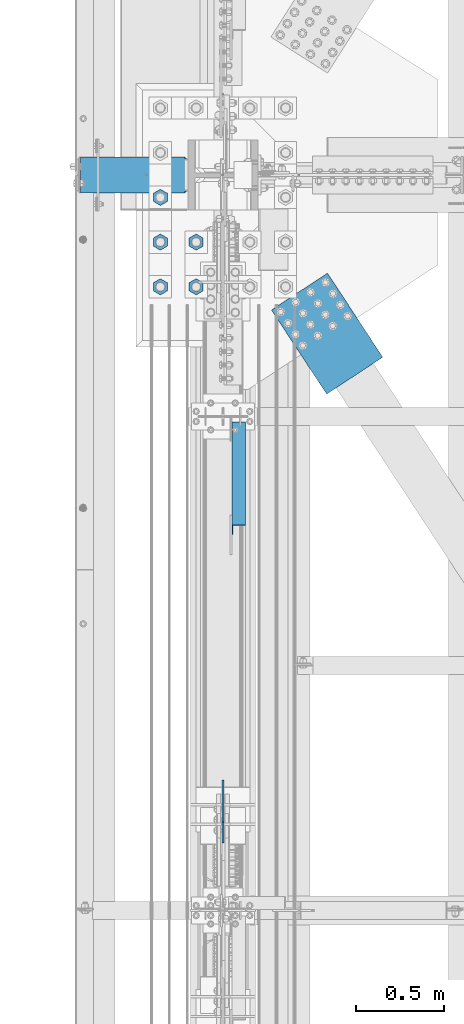
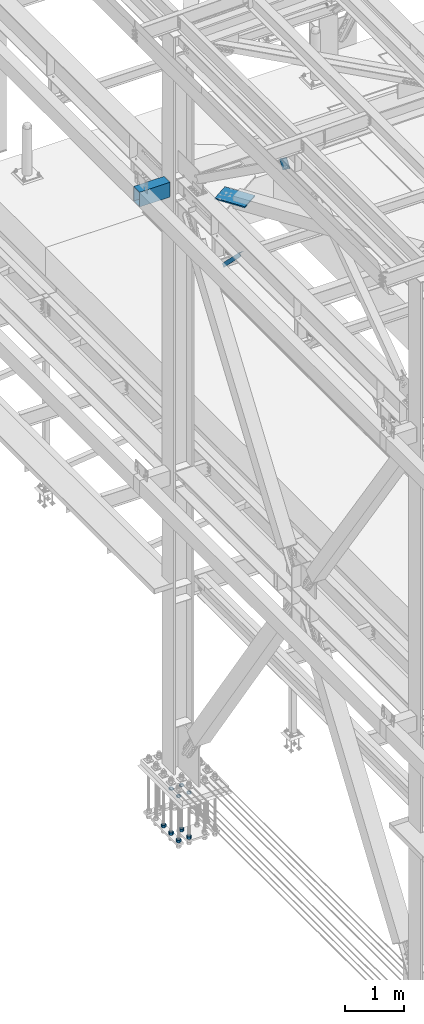
# One storey, part 2381 of 3843: 11 beams, 2 members, 5 elements without a shape of their own.
"""IFC2X3 building model written with IfcOpenShell, lengths in millimetres."""

from ifc_helpers import new_model, si_unit, frame, origin_with_axes, place, context, subcontext, project, spatial, faceted_brep, material, type_object, element, aggregate, save


model = new_model("IFC2X3")

# Units and contexts
model_context = context("Model", 3, precision=1e-05, world=origin_with_axes())
body_context = subcontext(model_context, "Body", "Model", "MODEL_VIEW")
ifc_project = project(units=[si_unit("LENGTHUNIT", "METRE", prefix="MILLI"), si_unit("AREAUNIT", "SQUARE_METRE"), si_unit("VOLUMEUNIT", "CUBIC_METRE"), si_unit("MASSUNIT", "GRAM", prefix="KILO"), si_unit("TIMEUNIT", "SECOND"), si_unit("PLANEANGLEUNIT", "RADIAN"), si_unit("SOLIDANGLEUNIT", "STERADIAN"), si_unit("THERMODYNAMICTEMPERATUREUNIT", "DEGREE_CELSIUS"), si_unit("LUMINOUSINTENSITYUNIT", "LUMEN")], contexts=[model_context])

# Site, building, storey
site_placement = place(None, origin_with_axes())
site = spatial("IfcSite", under=ifc_project, at=site_placement, CompositionType="ELEMENT")
building_placement = place(site_placement, origin_with_axes())
building = spatial("IfcBuilding", under=site, at=building_placement, Name="Undefined", CompositionType="ELEMENT")
storey_placement = place(building_placement, origin_with_axes())
storey = spatial("IfcBuildingStorey", under=building, at=storey_placement, Name="Undefined", CompositionType="ELEMENT", Elevation=0.0)

# Assembly, beams
assembly_1_placement = place(storey_placement, origin_with_axes())
assembly_1 = element("IfcElementAssembly", 1, at=assembly_1_placement, inside=storey, Name="TEMPLATE", AssemblyPlace="NOTDEFINED", PredefinedType="RIGID_FRAME")
ifc_material_1 = material(Name="STEEL/A572-50")
beam_type_1 = type_object("IfcBeamType", Name="2_HALF_NUT", PredefinedType="NOTDEFINED")
beam_1_placement = place(assembly_1_placement, frame((36220.4, 74993.5, 30060.9), z_axis=(-1.0, 0.0, 0.0), x_axis=(0.0, 0.0, -1.0)))
beam_1 = element("IfcBeam", 2, at=beam_1_placement, type_object=beam_type_1, material=ifc_material_1, Name="NUT", ObjectType="2_HALF_NUT", context=body_context, shape_type="Brep", body=[
    faceted_brep([(0.0, -46.0369987487793, 0.0), (0.0, -23.0184993743896, -39.869213104248), (25.4000000000015, -23.0184993743896, -39.869213104248), (25.4000000000015, -46.0369987487793, 0.0), (0.0, 23.0184993743896, -39.869213104248), (25.4000000000015, 23.0184993743896, -39.869213104248), (0.0, 46.0369987487793, 0.0), (25.4000000000015, 46.0369987487793, 0.0), (0.0, 23.0184993743896, 39.869213104248), (25.4000000000015, 23.0184993743896, 39.869213104248), (0.0, -23.0184993743896, 39.869213104248), (25.4000000000015, -23.0184993743896, 39.869213104248), (0.0, 0.0, 26.1940002441406), (0.0, 11.3650617044477, 23.5999013092805), (25.4000000000015, 11.3650617044477, 23.5999013092805), (25.4000000000015, 0.0, 26.1940002441406), (0.0, 20.4791109456419, 16.3316083006721), (25.4000000000015, 20.4791109456419, 16.3316083006721), (0.0, 25.5370200498292, 5.82867859874386), (25.4000000000015, 25.5370200498292, 5.82867859874386), (0.0, 25.5370200498292, -5.82867859874386), (25.4000000000015, 25.5370200498292, -5.82867859874386), (0.0, 20.4791109456419, -16.3316083006721), (25.4000000000015, 20.4791109456419, -16.3316083006721), (0.0, 11.3650617044477, -23.5999013092805), (25.4000000000015, 11.3650617044477, -23.5999013092805), (0.0, 0.0, -26.1940002441406), (25.4000000000015, 0.0, -26.1940002441406), (0.0, -11.3650617044477, -23.5999013092805), (25.4000000000015, -11.3650617044477, -23.5999013092805), (0.0, -20.4791109456419, -16.3316083006721), (25.4000000000015, -20.4791109456419, -16.3316083006721), (0.0, -25.5370200498292, -5.82867859874386), (25.4000000000015, -25.5370200498292, -5.82867859874386), (0.0, -25.5370200498292, 5.82867859874386), (25.4000000000015, -25.5370200498292, 5.82867859874386), (0.0, -20.4791109456419, 16.3316083006721), (25.4000000000015, -20.4791109456419, 16.3316083006721), (0.0, -11.3650617044477, 23.5999013092805), (25.4000000000015, -11.3650617044477, 23.5999013092805)], [[[0, 1, 2, 3]], [[1, 4, 5, 2]], [[4, 6, 7, 5]], [[6, 8, 9, 7]], [[8, 10, 11, 9]], [[10, 0, 3, 11]], [[12, 13, 14, 15]], [[13, 16, 17, 14]], [[16, 18, 19, 17]], [[18, 20, 21, 19]], [[20, 22, 23, 21]], [[22, 24, 25, 23]], [[24, 26, 27, 25]], [[26, 28, 29, 27]], [[28, 30, 31, 29]], [[30, 32, 33, 31]], [[32, 34, 35, 33]], [[34, 36, 37, 35]], [[36, 38, 39, 37]], [[38, 12, 15, 39]], [[5, 7, 9, 11, 3, 2], [17, 19, 21, 23, 25, 27, 29, 31, 33, 35, 37, 39, 15, 14]], [[10, 8, 6, 4, 1, 0], [38, 36, 34, 32, 30, 28, 26, 24, 22, 20, 18, 16, 13, 12]]]),
])
beam_2_placement = place(assembly_1_placement, frame((36423.6, 74993.5, 30060.9), z_axis=(-1.0, 0.0, 0.0), x_axis=(0.0, 0.0, -1.0)))
beam_2 = element("IfcBeam", 3, at=beam_2_placement, type_object=beam_type_1, material=ifc_material_1, Name="NUT", ObjectType="2_HALF_NUT", context=body_context, shape_type="Brep", body=[
    faceted_brep([(0.0, -46.0369987487793, 0.0), (0.0, -23.0184993743896, -39.869213104248), (25.4000000000015, -23.0184993743896, -39.869213104248), (25.4000000000015, -46.0369987487793, 0.0), (0.0, 23.0184993743896, -39.869213104248), (25.4000000000015, 23.0184993743896, -39.869213104248), (0.0, 46.0369987487793, 0.0), (25.4000000000015, 46.0369987487793, 0.0), (0.0, 23.0184993743896, 39.869213104248), (25.4000000000015, 23.0184993743896, 39.869213104248), (0.0, -23.0184993743896, 39.869213104248), (25.4000000000015, -23.0184993743896, 39.869213104248), (0.0, 0.0, 26.1940002441406), (0.0, 11.3650617044477, 23.5999013092805), (25.4000000000015, 11.3650617044477, 23.5999013092805), (25.4000000000015, 0.0, 26.1940002441406), (0.0, 20.4791109456419, 16.3316083006721), (25.4000000000015, 20.4791109456419, 16.3316083006721), (0.0, 25.5370200498292, 5.82867859874386), (25.4000000000015, 25.5370200498292, 5.82867859874386), (0.0, 25.5370200498292, -5.82867859874386), (25.4000000000015, 25.5370200498292, -5.82867859874386), (0.0, 20.4791109456419, -16.3316083006721), (25.4000000000015, 20.4791109456419, -16.3316083006721), (0.0, 11.3650617044477, -23.5999013092805), (25.4000000000015, 11.3650617044477, -23.5999013092805), (0.0, 0.0, -26.1940002441406), (25.4000000000015, 0.0, -26.1940002441406), (0.0, -11.3650617044477, -23.5999013092805), (25.4000000000015, -11.3650617044477, -23.5999013092805), (0.0, -20.4791109456419, -16.3316083006721), (25.4000000000015, -20.4791109456419, -16.3316083006721), (0.0, -25.5370200498292, -5.82867859874386), (25.4000000000015, -25.5370200498292, -5.82867859874386), (0.0, -25.5370200498292, 5.82867859874386), (25.4000000000015, -25.5370200498292, 5.82867859874386), (0.0, -20.4791109456419, 16.3316083006721), (25.4000000000015, -20.4791109456419, 16.3316083006721), (0.0, -11.3650617044477, 23.5999013092805), (25.4000000000015, -11.3650617044477, 23.5999013092805)], [[[0, 1, 2, 3]], [[1, 4, 5, 2]], [[4, 6, 7, 5]], [[6, 8, 9, 7]], [[8, 10, 11, 9]], [[10, 0, 3, 11]], [[12, 13, 14, 15]], [[13, 16, 17, 14]], [[16, 18, 19, 17]], [[18, 20, 21, 19]], [[20, 22, 23, 21]], [[22, 24, 25, 23]], [[24, 26, 27, 25]], [[26, 28, 29, 27]], [[28, 30, 31, 29]], [[30, 32, 33, 31]], [[32, 34, 35, 33]], [[34, 36, 37, 35]], [[36, 38, 39, 37]], [[38, 12, 15, 39]], [[5, 7, 9, 11, 3, 2], [17, 19, 21, 23, 25, 27, 29, 31, 33, 35, 37, 39, 15, 14]], [[10, 8, 6, 4, 1, 0], [38, 36, 34, 32, 30, 28, 26, 24, 22, 20, 18, 16, 13, 12]]]),
])
beam_3_placement = place(assembly_1_placement, frame((36423.6, 75247.5, 30060.9), z_axis=(-1.0, 0.0, 0.0), x_axis=(0.0, 0.0, -1.0)))
beam_3 = element("IfcBeam", 4, at=beam_3_placement, type_object=beam_type_1, material=ifc_material_1, Name="NUT", ObjectType="2_HALF_NUT", context=body_context, shape_type="Brep", body=[
    faceted_brep([(0.0, -46.0369987487793, 0.0), (0.0, -23.0184993743896, -39.869213104248), (25.4000000000015, -23.0184993743896, -39.869213104248), (25.4000000000015, -46.0369987487793, 0.0), (0.0, 23.0184993743896, -39.869213104248), (25.4000000000015, 23.0184993743896, -39.869213104248), (0.0, 46.0369987487793, 0.0), (25.4000000000015, 46.0369987487793, 0.0), (0.0, 23.0184993743896, 39.869213104248), (25.4000000000015, 23.0184993743896, 39.869213104248), (0.0, -23.0184993743896, 39.869213104248), (25.4000000000015, -23.0184993743896, 39.869213104248), (0.0, 0.0, 26.1940002441406), (0.0, 11.3650617044477, 23.5999013092805), (25.4000000000015, 11.3650617044477, 23.5999013092805), (25.4000000000015, 0.0, 26.1940002441406), (0.0, 20.4791109456419, 16.3316083006721), (25.4000000000015, 20.4791109456419, 16.3316083006721), (0.0, 25.5370200498292, 5.82867859874386), (25.4000000000015, 25.5370200498292, 5.82867859874386), (0.0, 25.5370200498292, -5.82867859874386), (25.4000000000015, 25.5370200498292, -5.82867859874386), (0.0, 20.4791109456419, -16.3316083006721), (25.4000000000015, 20.4791109456419, -16.3316083006721), (0.0, 11.3650617044477, -23.5999013092805), (25.4000000000015, 11.3650617044477, -23.5999013092805), (0.0, 0.0, -26.1940002441406), (25.4000000000015, 0.0, -26.1940002441406), (0.0, -11.3650617044477, -23.5999013092805), (25.4000000000015, -11.3650617044477, -23.5999013092805), (0.0, -20.4791109456419, -16.3316083006721), (25.4000000000015, -20.4791109456419, -16.3316083006721), (0.0, -25.5370200498292, -5.82867859874386), (25.4000000000015, -25.5370200498292, -5.82867859874386), (0.0, -25.5370200498292, 5.82867859874386), (25.4000000000015, -25.5370200498292, 5.82867859874386), (0.0, -20.4791109456419, 16.3316083006721), (25.4000000000015, -20.4791109456419, 16.3316083006721), (0.0, -11.3650617044477, 23.5999013092805), (25.4000000000015, -11.3650617044477, 23.5999013092805)], [[[0, 1, 2, 3]], [[1, 4, 5, 2]], [[4, 6, 7, 5]], [[6, 8, 9, 7]], [[8, 10, 11, 9]], [[10, 0, 3, 11]], [[12, 13, 14, 15]], [[13, 16, 17, 14]], [[16, 18, 19, 17]], [[18, 20, 21, 19]], [[20, 22, 23, 21]], [[22, 24, 25, 23]], [[24, 26, 27, 25]], [[26, 28, 29, 27]], [[28, 30, 31, 29]], [[30, 32, 33, 31]], [[32, 34, 35, 33]], [[34, 36, 37, 35]], [[36, 38, 39, 37]], [[38, 12, 15, 39]], [[5, 7, 9, 11, 3, 2], [17, 19, 21, 23, 25, 27, 29, 31, 33, 35, 37, 39, 15, 14]], [[10, 8, 6, 4, 1, 0], [38, 36, 34, 32, 30, 28, 26, 24, 22, 20, 18, 16, 13, 12]]]),
])
beam_4_placement = place(assembly_1_placement, frame((36220.4, 75247.5, 30060.9), z_axis=(-1.0, 0.0, 0.0), x_axis=(0.0, 0.0, -1.0)))
beam_4 = element("IfcBeam", 5, at=beam_4_placement, type_object=beam_type_1, material=ifc_material_1, Name="NUT", ObjectType="2_HALF_NUT", context=body_context, shape_type="Brep", body=[
    faceted_brep([(0.0, -46.0369987487793, 0.0), (0.0, -23.0184993743896, -39.869213104248), (25.4000000000015, -23.0184993743896, -39.869213104248), (25.4000000000015, -46.0369987487793, 0.0), (0.0, 23.0184993743896, -39.869213104248), (25.4000000000015, 23.0184993743896, -39.869213104248), (0.0, 46.0369987487793, 0.0), (25.4000000000015, 46.0369987487793, 0.0), (0.0, 23.0184993743896, 39.869213104248), (25.4000000000015, 23.0184993743896, 39.869213104248), (0.0, -23.0184993743896, 39.869213104248), (25.4000000000015, -23.0184993743896, 39.869213104248), (0.0, 0.0, 26.1940002441406), (0.0, 11.3650617044477, 23.5999013092805), (25.4000000000015, 11.3650617044477, 23.5999013092805), (25.4000000000015, 0.0, 26.1940002441406), (0.0, 20.4791109456419, 16.3316083006721), (25.4000000000015, 20.4791109456419, 16.3316083006721), (0.0, 25.5370200498292, 5.82867859874386), (25.4000000000015, 25.5370200498292, 5.82867859874386), (0.0, 25.5370200498292, -5.82867859874386), (25.4000000000015, 25.5370200498292, -5.82867859874386), (0.0, 20.4791109456419, -16.3316083006721), (25.4000000000015, 20.4791109456419, -16.3316083006721), (0.0, 11.3650617044477, -23.5999013092805), (25.4000000000015, 11.3650617044477, -23.5999013092805), (0.0, 0.0, -26.1940002441406), (25.4000000000015, 0.0, -26.1940002441406), (0.0, -11.3650617044477, -23.5999013092805), (25.4000000000015, -11.3650617044477, -23.5999013092805), (0.0, -20.4791109456419, -16.3316083006721), (25.4000000000015, -20.4791109456419, -16.3316083006721), (0.0, -25.5370200498292, -5.82867859874386), (25.4000000000015, -25.5370200498292, -5.82867859874386), (0.0, -25.5370200498292, 5.82867859874386), (25.4000000000015, -25.5370200498292, 5.82867859874386), (0.0, -20.4791109456419, 16.3316083006721), (25.4000000000015, -20.4791109456419, 16.3316083006721), (0.0, -11.3650617044477, 23.5999013092805), (25.4000000000015, -11.3650617044477, 23.5999013092805)], [[[0, 1, 2, 3]], [[1, 4, 5, 2]], [[4, 6, 7, 5]], [[6, 8, 9, 7]], [[8, 10, 11, 9]], [[10, 0, 3, 11]], [[12, 13, 14, 15]], [[13, 16, 17, 14]], [[16, 18, 19, 17]], [[18, 20, 21, 19]], [[20, 22, 23, 21]], [[22, 24, 25, 23]], [[24, 26, 27, 25]], [[26, 28, 29, 27]], [[28, 30, 31, 29]], [[30, 32, 33, 31]], [[32, 34, 35, 33]], [[34, 36, 37, 35]], [[36, 38, 39, 37]], [[38, 12, 15, 39]], [[5, 7, 9, 11, 3, 2], [17, 19, 21, 23, 25, 27, 29, 31, 33, 35, 37, 39, 15, 14]], [[10, 8, 6, 4, 1, 0], [38, 36, 34, 32, 30, 28, 26, 24, 22, 20, 18, 16, 13, 12]]]),
])
beam_type_2 = type_object("IfcBeamType", Name="2_HEAVY_HEX_NUT", PredefinedType="NOTDEFINED")
beam_5_placement = place(assembly_1_placement, frame((36423.6, 74993.5, 29159.2), z_axis=(-1.0, 0.0, 0.0), x_axis=(0.0, 0.0, -1.0)))
beam_5 = element("IfcBeam", 6, at=beam_5_placement, type_object=beam_type_2, material=ifc_material_1, Name="NUT", ObjectType="2_HEAVY_HEX_NUT", context=body_context, shape_type="Brep", body=[
    faceted_brep([(0.0, -46.0369987487793, 0.0), (0.0, -23.0184993743896, -39.869213104248), (50.7999999999993, -23.0184993743896, -39.869213104248), (50.7999999999993, -46.0369987487793, 0.0), (0.0, 23.0184993743896, -39.869213104248), (50.7999999999993, 23.0184993743896, -39.869213104248), (0.0, 46.0369987487793, 0.0), (50.7999999999993, 46.0369987487793, 0.0), (0.0, 23.0184993743896, 39.869213104248), (50.7999999999993, 23.0184993743896, 39.869213104248), (0.0, -23.0184993743896, 39.869213104248), (50.7999999999993, -23.0184993743896, 39.869213104248), (0.0, 0.0, 26.1940002441406), (0.0, 11.3650617044477, 23.5999013092805), (50.7999999999993, 11.3650617044477, 23.5999013092805), (50.7999999999993, 0.0, 26.1940002441406), (0.0, 20.4791109456419, 16.3316083006721), (50.7999999999993, 20.4791109456419, 16.3316083006721), (0.0, 25.5370200498292, 5.82867859874386), (50.7999999999993, 25.5370200498292, 5.82867859874386), (0.0, 25.5370200498292, -5.82867859874386), (50.7999999999993, 25.5370200498292, -5.82867859874386), (0.0, 20.4791109456419, -16.3316083006721), (50.7999999999993, 20.4791109456419, -16.3316083006721), (0.0, 11.3650617044477, -23.5999013092805), (50.7999999999993, 11.3650617044477, -23.5999013092805), (0.0, 0.0, -26.1940002441406), (50.7999999999993, 0.0, -26.1940002441406), (0.0, -11.3650617044477, -23.5999013092805), (50.7999999999993, -11.3650617044477, -23.5999013092805), (0.0, -20.4791109456419, -16.3316083006721), (50.7999999999993, -20.4791109456419, -16.3316083006721), (0.0, -25.5370200498292, -5.82867859874386), (50.7999999999993, -25.5370200498292, -5.82867859874386), (0.0, -25.5370200498292, 5.82867859874386), (50.7999999999993, -25.5370200498292, 5.82867859874386), (0.0, -20.4791109456419, 16.3316083006721), (50.7999999999993, -20.4791109456419, 16.3316083006721), (0.0, -11.3650617044477, 23.5999013092805), (50.7999999999993, -11.3650617044477, 23.5999013092805)], [[[0, 1, 2, 3]], [[1, 4, 5, 2]], [[4, 6, 7, 5]], [[6, 8, 9, 7]], [[8, 10, 11, 9]], [[10, 0, 3, 11]], [[12, 13, 14, 15]], [[13, 16, 17, 14]], [[16, 18, 19, 17]], [[18, 20, 21, 19]], [[20, 22, 23, 21]], [[22, 24, 25, 23]], [[24, 26, 27, 25]], [[26, 28, 29, 27]], [[28, 30, 31, 29]], [[30, 32, 33, 31]], [[32, 34, 35, 33]], [[34, 36, 37, 35]], [[36, 38, 39, 37]], [[38, 12, 15, 39]], [[5, 7, 9, 11, 3, 2], [17, 19, 21, 23, 25, 27, 29, 31, 33, 35, 37, 39, 15, 14]], [[10, 8, 6, 4, 1, 0], [38, 36, 34, 32, 30, 28, 26, 24, 22, 20, 18, 16, 13, 12]]]),
])
beam_6_placement = place(assembly_1_placement, frame((36423.6, 75247.5, 29159.2), z_axis=(-1.0, 0.0, 0.0), x_axis=(0.0, 0.0, -1.0)))
beam_6 = element("IfcBeam", 7, at=beam_6_placement, type_object=beam_type_2, material=ifc_material_1, Name="NUT", ObjectType="2_HEAVY_HEX_NUT", context=body_context, shape_type="Brep", body=[
    faceted_brep([(0.0, -46.0369987487793, 0.0), (0.0, -23.0184993743896, -39.869213104248), (50.7999999999993, -23.0184993743896, -39.869213104248), (50.7999999999993, -46.0369987487793, 0.0), (0.0, 23.0184993743896, -39.869213104248), (50.7999999999993, 23.0184993743896, -39.869213104248), (0.0, 46.0369987487793, 0.0), (50.7999999999993, 46.0369987487793, 0.0), (0.0, 23.0184993743896, 39.869213104248), (50.7999999999993, 23.0184993743896, 39.869213104248), (0.0, -23.0184993743896, 39.869213104248), (50.7999999999993, -23.0184993743896, 39.869213104248), (0.0, 0.0, 26.1940002441406), (0.0, 11.3650617044477, 23.5999013092805), (50.7999999999993, 11.3650617044477, 23.5999013092805), (50.7999999999993, 0.0, 26.1940002441406), (0.0, 20.4791109456419, 16.3316083006721), (50.7999999999993, 20.4791109456419, 16.3316083006721), (0.0, 25.5370200498292, 5.82867859874386), (50.7999999999993, 25.5370200498292, 5.82867859874386), (0.0, 25.5370200498292, -5.82867859874386), (50.7999999999993, 25.5370200498292, -5.82867859874386), (0.0, 20.4791109456419, -16.3316083006721), (50.7999999999993, 20.4791109456419, -16.3316083006721), (0.0, 11.3650617044477, -23.5999013092805), (50.7999999999993, 11.3650617044477, -23.5999013092805), (0.0, 0.0, -26.1940002441406), (50.7999999999993, 0.0, -26.1940002441406), (0.0, -11.3650617044477, -23.5999013092805), (50.7999999999993, -11.3650617044477, -23.5999013092805), (0.0, -20.4791109456419, -16.3316083006721), (50.7999999999993, -20.4791109456419, -16.3316083006721), (0.0, -25.5370200498292, -5.82867859874386), (50.7999999999993, -25.5370200498292, -5.82867859874386), (0.0, -25.5370200498292, 5.82867859874386), (50.7999999999993, -25.5370200498292, 5.82867859874386), (0.0, -20.4791109456419, 16.3316083006721), (50.7999999999993, -20.4791109456419, 16.3316083006721), (0.0, -11.3650617044477, 23.5999013092805), (50.7999999999993, -11.3650617044477, 23.5999013092805)], [[[0, 1, 2, 3]], [[1, 4, 5, 2]], [[4, 6, 7, 5]], [[6, 8, 9, 7]], [[8, 10, 11, 9]], [[10, 0, 3, 11]], [[12, 13, 14, 15]], [[13, 16, 17, 14]], [[16, 18, 19, 17]], [[18, 20, 21, 19]], [[20, 22, 23, 21]], [[22, 24, 25, 23]], [[24, 26, 27, 25]], [[26, 28, 29, 27]], [[28, 30, 31, 29]], [[30, 32, 33, 31]], [[32, 34, 35, 33]], [[34, 36, 37, 35]], [[36, 38, 39, 37]], [[38, 12, 15, 39]], [[5, 7, 9, 11, 3, 2], [17, 19, 21, 23, 25, 27, 29, 31, 33, 35, 37, 39, 15, 14]], [[10, 8, 6, 4, 1, 0], [38, 36, 34, 32, 30, 28, 26, 24, 22, 20, 18, 16, 13, 12]]]),
])
beam_7_placement = place(assembly_1_placement, frame((36220.4, 75501.5, 29159.2), z_axis=(1.0, 0.0, 0.0), x_axis=(0.0, 0.0, -1.0)))
beam_7 = element("IfcBeam", 8, at=beam_7_placement, type_object=beam_type_2, material=ifc_material_1, Name="NUT", ObjectType="2_HEAVY_HEX_NUT", context=body_context, shape_type="Brep", body=[
    faceted_brep([(0.0, -46.0369987487793, 0.0), (0.0, -23.0184993743896, -39.869213104248), (50.7999999999993, -23.0184993743896, -39.869213104248), (50.7999999999993, -46.0369987487793, 0.0), (0.0, 23.0184993743896, -39.869213104248), (50.7999999999993, 23.0184993743896, -39.869213104248), (0.0, 46.0369987487793, 0.0), (50.7999999999993, 46.0369987487793, 0.0), (0.0, 23.0184993743896, 39.869213104248), (50.7999999999993, 23.0184993743896, 39.869213104248), (0.0, -23.0184993743896, 39.869213104248), (50.7999999999993, -23.0184993743896, 39.869213104248), (0.0, 0.0, 26.1940002441406), (0.0, 11.3650617044477, 23.5999013092805), (50.7999999999993, 11.3650617044477, 23.5999013092805), (50.7999999999993, 0.0, 26.1940002441406), (0.0, 20.4791109456419, 16.3316083006721), (50.7999999999993, 20.4791109456419, 16.3316083006721), (0.0, 25.5370200498292, 5.82867859874386), (50.7999999999993, 25.5370200498292, 5.82867859874386), (0.0, 25.5370200498292, -5.82867859874386), (50.7999999999993, 25.5370200498292, -5.82867859874386), (0.0, 20.4791109456419, -16.3316083006721), (50.7999999999993, 20.4791109456419, -16.3316083006721), (0.0, 11.3650617044477, -23.5999013092805), (50.7999999999993, 11.3650617044477, -23.5999013092805), (0.0, 0.0, -26.1940002441406), (50.7999999999993, 0.0, -26.1940002441406), (0.0, -11.3650617044477, -23.5999013092805), (50.7999999999993, -11.3650617044477, -23.5999013092805), (0.0, -20.4791109456419, -16.3316083006721), (50.7999999999993, -20.4791109456419, -16.3316083006721), (0.0, -25.5370200498292, -5.82867859874386), (50.7999999999993, -25.5370200498292, -5.82867859874386), (0.0, -25.5370200498292, 5.82867859874386), (50.7999999999993, -25.5370200498292, 5.82867859874386), (0.0, -20.4791109456419, 16.3316083006721), (50.7999999999993, -20.4791109456419, 16.3316083006721), (0.0, -11.3650617044477, 23.5999013092805), (50.7999999999993, -11.3650617044477, 23.5999013092805)], [[[0, 1, 2, 3]], [[1, 4, 5, 2]], [[4, 6, 7, 5]], [[6, 8, 9, 7]], [[8, 10, 11, 9]], [[10, 0, 3, 11]], [[12, 13, 14, 15]], [[13, 16, 17, 14]], [[16, 18, 19, 17]], [[18, 20, 21, 19]], [[20, 22, 23, 21]], [[22, 24, 25, 23]], [[24, 26, 27, 25]], [[26, 28, 29, 27]], [[28, 30, 31, 29]], [[30, 32, 33, 31]], [[32, 34, 35, 33]], [[34, 36, 37, 35]], [[36, 38, 39, 37]], [[38, 12, 15, 39]], [[5, 7, 9, 11, 3, 2], [17, 19, 21, 23, 25, 27, 29, 31, 33, 35, 37, 39, 15, 14]], [[10, 8, 6, 4, 1, 0], [38, 36, 34, 32, 30, 28, 26, 24, 22, 20, 18, 16, 13, 12]]]),
])
beam_8_placement = place(assembly_1_placement, frame((36220.4, 75247.5, 29159.2), z_axis=(-1.0, 0.0, 0.0), x_axis=(0.0, 0.0, -1.0)))
beam_8 = element("IfcBeam", 9, at=beam_8_placement, type_object=beam_type_2, material=ifc_material_1, Name="NUT", ObjectType="2_HEAVY_HEX_NUT", context=body_context, shape_type="Brep", body=[
    faceted_brep([(0.0, -46.0369987487793, 0.0), (0.0, -23.0184993743896, -39.869213104248), (50.7999999999993, -23.0184993743896, -39.869213104248), (50.7999999999993, -46.0369987487793, 0.0), (0.0, 23.0184993743896, -39.869213104248), (50.7999999999993, 23.0184993743896, -39.869213104248), (0.0, 46.0369987487793, 0.0), (50.7999999999993, 46.0369987487793, 0.0), (0.0, 23.0184993743896, 39.869213104248), (50.7999999999993, 23.0184993743896, 39.869213104248), (0.0, -23.0184993743896, 39.869213104248), (50.7999999999993, -23.0184993743896, 39.869213104248), (0.0, 0.0, 26.1940002441406), (0.0, 11.3650617044477, 23.5999013092805), (50.7999999999993, 11.3650617044477, 23.5999013092805), (50.7999999999993, 0.0, 26.1940002441406), (0.0, 20.4791109456419, 16.3316083006721), (50.7999999999993, 20.4791109456419, 16.3316083006721), (0.0, 25.5370200498292, 5.82867859874386), (50.7999999999993, 25.5370200498292, 5.82867859874386), (0.0, 25.5370200498292, -5.82867859874386), (50.7999999999993, 25.5370200498292, -5.82867859874386), (0.0, 20.4791109456419, -16.3316083006721), (50.7999999999993, 20.4791109456419, -16.3316083006721), (0.0, 11.3650617044477, -23.5999013092805), (50.7999999999993, 11.3650617044477, -23.5999013092805), (0.0, 0.0, -26.1940002441406), (50.7999999999993, 0.0, -26.1940002441406), (0.0, -11.3650617044477, -23.5999013092805), (50.7999999999993, -11.3650617044477, -23.5999013092805), (0.0, -20.4791109456419, -16.3316083006721), (50.7999999999993, -20.4791109456419, -16.3316083006721), (0.0, -25.5370200498292, -5.82867859874386), (50.7999999999993, -25.5370200498292, -5.82867859874386), (0.0, -25.5370200498292, 5.82867859874386), (50.7999999999993, -25.5370200498292, 5.82867859874386), (0.0, -20.4791109456419, 16.3316083006721), (50.7999999999993, -20.4791109456419, 16.3316083006721), (0.0, -11.3650617044477, 23.5999013092805), (50.7999999999993, -11.3650617044477, 23.5999013092805)], [[[0, 1, 2, 3]], [[1, 4, 5, 2]], [[4, 6, 7, 5]], [[6, 8, 9, 7]], [[8, 10, 11, 9]], [[10, 0, 3, 11]], [[12, 13, 14, 15]], [[13, 16, 17, 14]], [[16, 18, 19, 17]], [[18, 20, 21, 19]], [[20, 22, 23, 21]], [[22, 24, 25, 23]], [[24, 26, 27, 25]], [[26, 28, 29, 27]], [[28, 30, 31, 29]], [[30, 32, 33, 31]], [[32, 34, 35, 33]], [[34, 36, 37, 35]], [[36, 38, 39, 37]], [[38, 12, 15, 39]], [[5, 7, 9, 11, 3, 2], [17, 19, 21, 23, 25, 27, 29, 31, 33, 35, 37, 39, 15, 14]], [[10, 8, 6, 4, 1, 0], [38, 36, 34, 32, 30, 28, 26, 24, 22, 20, 18, 16, 13, 12]]]),
])
beam_9_placement = place(assembly_1_placement, frame((36220.4, 74993.5, 29159.2), z_axis=(-1.0, 0.0, 0.0), x_axis=(0.0, 0.0, -1.0)))
beam_9 = element("IfcBeam", 10, at=beam_9_placement, type_object=beam_type_2, material=ifc_material_1, Name="NUT", ObjectType="2_HEAVY_HEX_NUT", context=body_context, shape_type="Brep", body=[
    faceted_brep([(0.0, -46.0369987487793, 0.0), (0.0, -23.0184993743896, -39.869213104248), (50.7999999999993, -23.0184993743896, -39.869213104248), (50.7999999999993, -46.0369987487793, 0.0), (0.0, 23.0184993743896, -39.869213104248), (50.7999999999993, 23.0184993743896, -39.869213104248), (0.0, 46.0369987487793, 0.0), (50.7999999999993, 46.0369987487793, 0.0), (0.0, 23.0184993743896, 39.869213104248), (50.7999999999993, 23.0184993743896, 39.869213104248), (0.0, -23.0184993743896, 39.869213104248), (50.7999999999993, -23.0184993743896, 39.869213104248), (0.0, 0.0, 26.1940002441406), (0.0, 11.3650617044477, 23.5999013092805), (50.7999999999993, 11.3650617044477, 23.5999013092805), (50.7999999999993, 0.0, 26.1940002441406), (0.0, 20.4791109456419, 16.3316083006721), (50.7999999999993, 20.4791109456419, 16.3316083006721), (0.0, 25.5370200498292, 5.82867859874386), (50.7999999999993, 25.5370200498292, 5.82867859874386), (0.0, 25.5370200498292, -5.82867859874386), (50.7999999999993, 25.5370200498292, -5.82867859874386), (0.0, 20.4791109456419, -16.3316083006721), (50.7999999999993, 20.4791109456419, -16.3316083006721), (0.0, 11.3650617044477, -23.5999013092805), (50.7999999999993, 11.3650617044477, -23.5999013092805), (0.0, 0.0, -26.1940002441406), (50.7999999999993, 0.0, -26.1940002441406), (0.0, -11.3650617044477, -23.5999013092805), (50.7999999999993, -11.3650617044477, -23.5999013092805), (0.0, -20.4791109456419, -16.3316083006721), (50.7999999999993, -20.4791109456419, -16.3316083006721), (0.0, -25.5370200498292, -5.82867859874386), (50.7999999999993, -25.5370200498292, -5.82867859874386), (0.0, -25.5370200498292, 5.82867859874386), (50.7999999999993, -25.5370200498292, 5.82867859874386), (0.0, -20.4791109456419, 16.3316083006721), (50.7999999999993, -20.4791109456419, 16.3316083006721), (0.0, -11.3650617044477, 23.5999013092805), (50.7999999999993, -11.3650617044477, 23.5999013092805)], [[[0, 1, 2, 3]], [[1, 4, 5, 2]], [[4, 6, 7, 5]], [[6, 8, 9, 7]], [[8, 10, 11, 9]], [[10, 0, 3, 11]], [[12, 13, 14, 15]], [[13, 16, 17, 14]], [[16, 18, 19, 17]], [[18, 20, 21, 19]], [[20, 22, 23, 21]], [[22, 24, 25, 23]], [[24, 26, 27, 25]], [[26, 28, 29, 27]], [[28, 30, 31, 29]], [[30, 32, 33, 31]], [[32, 34, 35, 33]], [[34, 36, 37, 35]], [[36, 38, 39, 37]], [[38, 12, 15, 39]], [[5, 7, 9, 11, 3, 2], [17, 19, 21, 23, 25, 27, 29, 31, 33, 35, 37, 39, 15, 14]], [[10, 8, 6, 4, 1, 0], [38, 36, 34, 32, 30, 28, 26, 24, 22, 20, 18, 16, 13, 12]]]),
])
aggregate(assembly_1, [beam_5, beam_6, beam_7, beam_8, beam_9, beam_1, beam_2, beam_3, beam_4])

# Assembly, member
assembly_2_placement = place(storey_placement, origin_with_axes())
assembly_2 = element("IfcElementAssembly", 11, at=assembly_2_placement, inside=storey, AssemblyPlace="NOTDEFINED", PredefinedType="RIGID_FRAME")
member_type_1 = type_object("IfcMemberType", PredefinedType="NOTDEFINED")
member_1_placement = place(assembly_2_placement, frame((36575.9999999316, 71893.6797219485, 44894.3152511977), z_axis=(0.0, -0.580418429799653, -0.814318393718885), x_axis=(0.0, 0.814318393718894, -0.580418429799641)))
member_1 = element("IfcMember", 12, at=member_1_placement, type_object=member_type_1, material=ifc_material_1, Name="PLATE", context=body_context, shape_type="Brep", body=[
    faceted_brep([(1.74622982740402e-10, 6.35000000000582, -101.600000000195), (-1.67347025126219e-10, 6.35000000000582, 101.600000000151), (292.1000000028, 6.35000000000582, 101.600000000661), (292.100000003156, 6.35000000000582, -101.599999999686), (-1.67347025126219e-10, -6.35000000000582, 101.600000000151), (292.1000000028, -6.35000000000582, 101.600000000661), (1.74622982740402e-10, -6.35000000000582, -101.600000000195), (292.100000003156, -6.35000000000582, -101.599999999686)], [[[0, 1, 2, 3]], [[1, 4, 5, 2]], [[4, 6, 7, 5]], [[6, 0, 3, 7]], [[5, 7, 3, 2]], [[6, 4, 1, 0]]]),
])
aggregate(assembly_2, [member_1])

# Assembly, beam
assembly_3_placement = place(storey_placement, origin_with_axes())
assembly_3 = element("IfcElementAssembly", 13, at=assembly_3_placement, inside=storey, Name="COLUMN", AssemblyPlace="NOTDEFINED", PredefinedType="RIGID_FRAME")
ifc_material_2 = material()
beam_type_3 = type_object("IfcBeamType", Name="HSS12X8X3/8", PredefinedType="NOTDEFINED")
beam_10_placement = place(assembly_3_placement, frame((35760.025, 75628.5, 42214.8), z_axis=(0.0, 0.0, 1.0), x_axis=(1.0, 0.0, 0.0)))
beam_10 = element("IfcBeam", 14, at=beam_10_placement, type_object=beam_type_3, material=ifc_material_2, Name="GIRT", ObjectType="HSS12X8X3/8", context=body_context, shape_type="Brep", body=[
    faceted_brep([(609.600000000006, 92.0749999999971, 142.875), (609.600000000006, 92.0749999999971, -142.875), (600.075000000004, 101.600000000006, -152.400000000001), (600.075000000004, 101.600000000006, 152.400000000001), (609.600000000006, -92.0749999999971, -142.875), (600.075000000004, -101.600000000006, -152.400000000001), (609.600000000006, -92.0749999999971, 142.875), (600.075000000004, -101.600000000006, 152.400000000001), (6.35000000002037, 92.0749999999971, 142.875), (6.35000000002037, 92.0749999999971, -142.875), (6.35000000002037, -92.0749999999971, 142.875), (6.35000000002037, -92.0749999999971, -142.875), (6.35000000002037, -101.600000000006, -152.400000000001), (6.35000000002037, -101.600000000006, 152.400000000001), (6.35000000002037, 101.600000000006, 152.400000000001), (6.35000000002037, 101.600000000006, -152.400000000001)], [[[0, 1, 2, 3]], [[4, 5, 2, 1]], [[6, 7, 5, 4]], [[8, 9, 1, 0]], [[10, 8, 0, 6]], [[11, 10, 6, 4]], [[9, 11, 4, 1]], [[12, 13, 14, 15], [8, 10, 11, 9]], [[15, 14, 3, 2]], [[12, 15, 2, 5]], [[13, 12, 5, 7]], [[14, 13, 7, 3]], [[0, 3, 7, 6]]]),
])
aggregate(assembly_3, [beam_10])

# Assembly, member
assembly_4_placement = place(storey_placement, origin_with_axes())
assembly_4 = element("IfcElementAssembly", 15, at=assembly_4_placement, inside=storey, Name="ANGLE", AssemblyPlace="NOTDEFINED", PredefinedType="RIGID_FRAME")
member_type_2 = type_object("IfcMemberType", Name="L3X3X1/4", PredefinedType="NOTDEFINED")
member_2_placement = place(assembly_4_placement, frame((36664.9, 74256.9, 41300.4), z_axis=(0.0, -0.707106781186548, -0.707106781186548), x_axis=(0.0, -0.707106781186682, 0.707106781186413)))
member_2 = element("IfcMember", 16, at=member_2_placement, type_object=member_type_2, material=ifc_material_1, Name="ANGLE", ObjectType="L3X3X1/4", context=body_context, shape_type="Brep", body=[
    faceted_brep([(83.0012806675732, 38.0999999999985, -38.0999999999058), (83.0012806675732, -38.0999999999985, -38.0999999999058), (83.0012806675804, -38.0999999999985, -31.7499999999254), (83.0012806675804, 31.75, -31.7499999999254), (83.0012806675804, 31.75, 38.0999999999058), (83.0012806675804, 38.0999999999985, 38.0999999999058), (909.31702238756, 31.75, 38.099999999904), (909.31702238756, 38.0999999999985, 38.099999999904), (909.317022387171, 38.0999999999985, -38.099999999904), (909.317022387171, -38.0999999999985, -38.099999999904), (909.317022387208, -38.0999999999985, -31.7499999999127), (909.317022387208, 31.75, -31.7499999999127)], [[[0, 1, 2, 3, 4, 5]], [[5, 4, 6, 7]], [[0, 5, 7, 8]], [[1, 0, 8, 9]], [[2, 1, 9, 10]], [[3, 2, 10, 11]], [[4, 3, 11, 6]], [[10, 9, 8, 7, 6, 11]]]),
])
aggregate(assembly_4, [member_2])

# Assembly, beam
assembly_5_placement = place(storey_placement, origin_with_axes())
assembly_5 = element("IfcElementAssembly", 17, at=assembly_5_placement, inside=storey, AssemblyPlace="NOTDEFINED", PredefinedType="RIGID_FRAME")
beam_type_4 = type_object("IfcBeamType", PredefinedType="NOTDEFINED")
beam_11_placement = place(assembly_5_placement, frame((37010.6228714812, 74966.5049785432, 42259.2516278841), z_axis=(-0.835938629021657, -0.548822930014219, 0.0), x_axis=(0.548822930014218, -0.835938629021658, 0.0)))
beam_11 = element("IfcBeam", 18, at=beam_11_placement, type_object=beam_type_4, material=ifc_material_1, Name="PLATE", context=body_context, shape_type="Brep", body=[
    faceted_brep([(5.85714587941766e-10, 12.6999999999971, -190.500000000349), (-6.14818418398499e-10, 12.6999999999971, 190.500000000364), (571.499999996191, 12.6999999999971, 190.49999999936), (571.499999997392, 12.6999999999971, -190.500000001353), (-6.14818418398499e-10, -12.6999999999971, 190.500000000364), (571.499999996191, -12.6999999999971, 190.49999999936), (5.85714587941766e-10, -12.6999999999971, -190.500000000349), (571.499999997392, -12.6999999999971, -190.500000001353)], [[[0, 1, 2, 3]], [[1, 4, 5, 2]], [[4, 6, 7, 5]], [[6, 0, 3, 7]], [[5, 7, 3, 2]], [[6, 4, 1, 0]]]),
])
aggregate(assembly_5, [beam_11])

save(model, "model.ifc")
